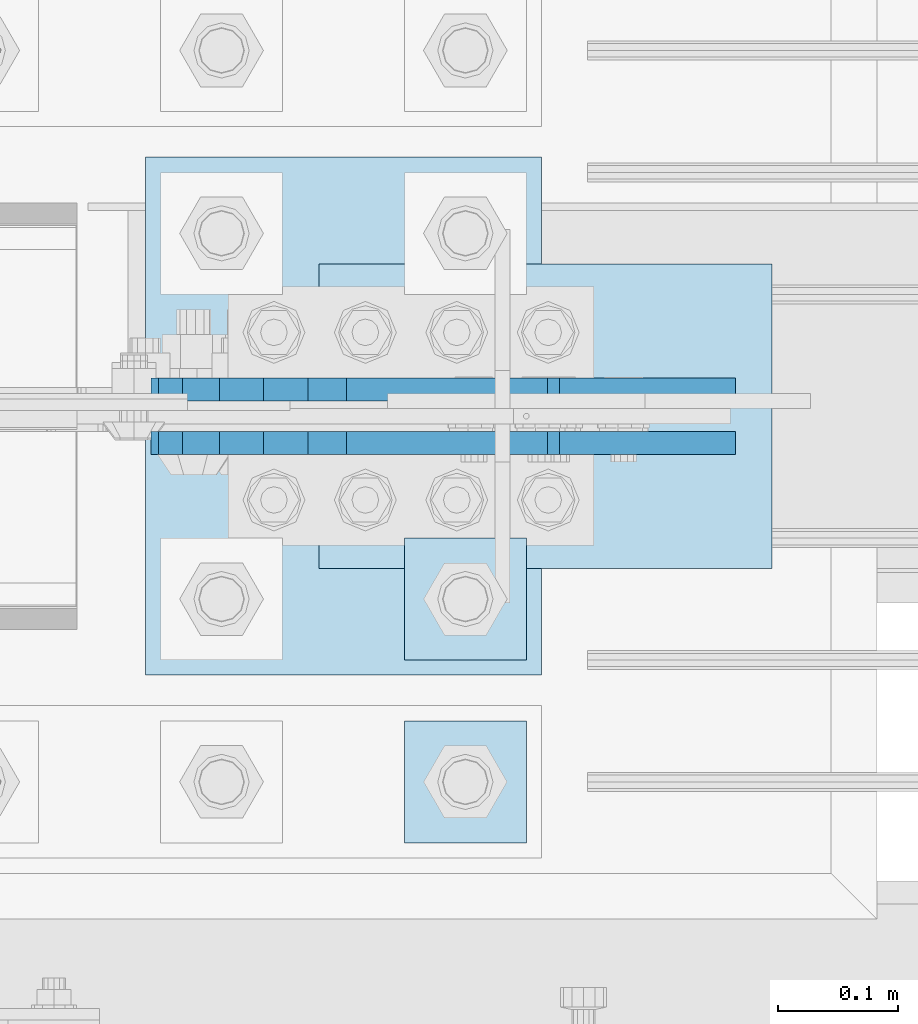
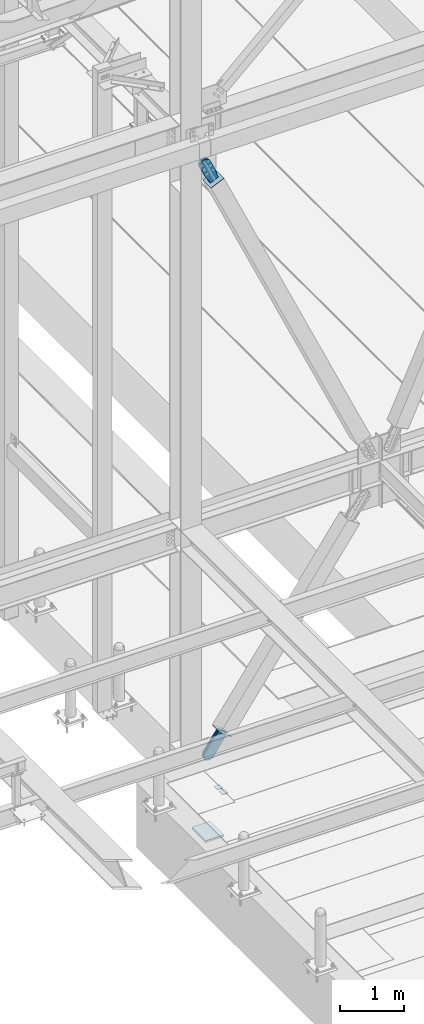
# One storey, part 3032 of 3843: 9 plates, 7 elements without a shape of their own.
"""IFC2X3 building model written with IfcOpenShell, lengths in millimetres."""

from ifc_helpers import new_model, si_unit, frame, origin_with_axes, place, context, subcontext, project, spatial, faceted_brep, material, type_object, element, aggregate, save


model = new_model("IFC2X3")

# Units and contexts
model_context = context("Model", 3, precision=1e-05, world=origin_with_axes())
body_context = subcontext(model_context, "Body", "Model", "MODEL_VIEW")
ifc_project = project(units=[si_unit("LENGTHUNIT", "METRE", prefix="MILLI"), si_unit("AREAUNIT", "SQUARE_METRE"), si_unit("VOLUMEUNIT", "CUBIC_METRE"), si_unit("MASSUNIT", "GRAM", prefix="KILO"), si_unit("TIMEUNIT", "SECOND"), si_unit("PLANEANGLEUNIT", "RADIAN"), si_unit("SOLIDANGLEUNIT", "STERADIAN"), si_unit("THERMODYNAMICTEMPERATUREUNIT", "DEGREE_CELSIUS"), si_unit("LUMINOUSINTENSITYUNIT", "LUMEN")], contexts=[model_context])

# Site, building, storey
site_placement = place(None, origin_with_axes())
site = spatial("IfcSite", under=ifc_project, at=site_placement, CompositionType="ELEMENT")
building_placement = place(site_placement, origin_with_axes())
building = spatial("IfcBuilding", under=site, at=building_placement, Name="Undefined", CompositionType="ELEMENT")
storey_placement = place(building_placement, origin_with_axes())
storey = spatial("IfcBuildingStorey", under=building, at=storey_placement, Name="Undefined", CompositionType="ELEMENT", Elevation=0.0)

# Assembly, plates
assembly_1_placement = place(storey_placement, origin_with_axes())
assembly_1 = element("IfcElementAssembly", 1, at=assembly_1_placement, inside=storey, Name="TEMPLATE", AssemblyPlace="NOTDEFINED", PredefinedType="RIGID_FRAME")
ifc_material_1 = material(Name="STEEL/A572-50")
plate_type_1 = type_object("IfcPlateType", PredefinedType="NOTDEFINED")
plate_1_placement = place(assembly_1_placement, frame((42621.2, 25361.9, 29686.25), z_axis=(-1.0, 0.0, 0.0), x_axis=(0.0, -1.0, 0.0)))
plate_1 = element("IfcPlate", 2, at=plate_1_placement, type_object=plate_type_1, material=ifc_material_1, Name="Washer Plate", context=body_context, shape_type="Brep", body=[
    faceted_brep([(0.0, -6.3499999046162, 0.0), (-1.67347025126219e-10, -6.35000000000582, 101.600000000151), (-1.67347025126219e-10, 6.35000000000582, 101.600000000151), (7.27595761418343e-12, 6.3499999046162, 0.0), (101.599998474121, -6.34999999999854, 101.599998474121), (101.599998474121, 6.34999999999854, 101.599998474121), (101.6, -6.34999999999854, 0.0), (101.6, 6.34999999999854, 0.0)], [[[0, 1, 2, 3]], [[1, 4, 5, 2]], [[4, 6, 7, 5]], [[6, 0, 3, 7]], [[5, 7, 3, 2]], [[6, 4, 1, 0]]]),
])
plate_2_placement = place(assembly_1_placement, frame((42621.2, 25514.3, 29686.25), z_axis=(-1.0, 0.0, 0.0), x_axis=(0.0, -1.0, 0.0)))
plate_2 = element("IfcPlate", 3, at=plate_2_placement, type_object=plate_type_1, material=ifc_material_1, Name="Washer Plate", context=body_context, shape_type="Brep", body=[
    faceted_brep([(0.0, -6.3499999046162, 0.0), (-1.67347025126219e-10, -6.35000000000582, 101.600000000151), (-1.67347025126219e-10, 6.35000000000582, 101.600000000151), (7.27595761418343e-12, 6.3499999046162, 0.0), (101.599998474121, -6.34999999999854, 101.599998474121), (101.599998474121, 6.34999999999854, 101.599998474121), (101.6, -6.34999999999854, 0.0), (101.6, 6.34999999999854, 0.0)], [[[0, 1, 2, 3]], [[1, 4, 5, 2]], [[4, 6, 7, 5]], [[6, 0, 3, 7]], [[5, 7, 3, 2]], [[6, 4, 1, 0]]]),
])

# Assembly, plate
assembly_2_placement = place(storey_placement, origin_with_axes())
assembly_2 = element("IfcElementAssembly", 4, at=assembly_2_placement, inside=storey, AssemblyPlace="NOTDEFINED", PredefinedType="RIGID_FRAME")
ifc_material_2 = material(Name="STEEL/A36")
plate_type_2 = type_object("IfcPlateType", PredefinedType="NOTDEFINED")
plate_3_placement = place(assembly_2_placement, frame((42755.4067779635, 25638.125, 30504.1943722968), z_axis=(-0.816439959974273, 0.0, 0.577430334981813), x_axis=(0.577430334981806, 0.0, 0.816439959974278)))
plate_3 = element("IfcPlate", 5, at=plate_3_placement, type_object=plate_type_2, material=ifc_material_2, context=body_context, shape_type="Brep", body=[
    faceted_brep([(0.0, -9.52500000000146, 0.0), (-101.59999999866, -9.52499999999418, -7.01164927375794), (-101.59999999866, 9.52499999999418, -7.01164927375794), (0.0, 9.52500000000146, 0.0), (-364.729297655074, -9.52499999999418, -7.01164927444188), (-364.729297655074, 9.52499999999418, -7.01164927444188), (-401.787405121293, -9.52499999999418, 0.359666612348519), (-401.787405121293, 9.52499999999418, 0.359666612348519), (-433.203751657995, -9.52499999999418, 21.3513982502482), (-433.203751657995, 9.52499999999418, 21.3513982502482), (-454.195483294687, -9.52499999999418, 52.7677447877504), (-454.195483294687, 9.52499999999418, 52.7677447877504), (-461.566799180051, -9.52499999999418, 89.8258492000314), (-461.566799180051, 9.52499999999418, 89.8258492000314), (-454.195483292249, -9.52499999999418, 126.883956664562), (-454.195483292249, 9.52499999999418, 126.883956664562), (-433.203751654662, -9.52499999999418, 158.300303199998), (-433.203751654662, 9.52499999999418, 158.300303199998), (-401.787405118426, -9.52499999999418, 179.292034836384), (-401.787405118426, 9.52499999999418, 179.292034836384), (-364.729299177612, -9.52499999999418, 186.663350722738), (-364.729299177612, 9.52499999999418, 186.663350722738), (-101.5999999907, -9.52499999999418, 186.663350723451), (-101.5999999907, 9.52499999999418, 186.663350723451), (7.37782102078199e-09, -9.52499999999418, 179.651701450231), (7.37782102078199e-09, 9.52499999999418, 179.651701450231), (69.8500000062704, -9.52499999999418, 179.651701450392), (69.8500000062704, 9.52499999999418, 179.651701450392), (69.8499999979995, -9.52499999999418, -4.00177668780088e-10), (69.8499999979995, 9.52499999999418, -4.00177668780088e-10)], [[[0, 1, 2, 3]], [[1, 4, 5, 2]], [[4, 6, 7, 5]], [[6, 8, 9, 7]], [[8, 10, 11, 9]], [[10, 12, 13, 11]], [[12, 14, 15, 13]], [[14, 16, 17, 15]], [[16, 18, 19, 17]], [[18, 20, 21, 19]], [[20, 22, 23, 21]], [[22, 24, 25, 23]], [[24, 26, 27, 25]], [[26, 28, 29, 27]], [[28, 0, 3, 29]], [[5, 7, 9, 11, 13, 15, 17, 19, 21, 23, 25, 27, 29, 3, 2]], [[28, 26, 24, 22, 20, 18, 16, 14, 12, 10, 8, 6, 4, 1, 0]]]),
])
aggregate(assembly_2, [plate_3])

assembly_3_placement = place(storey_placement, origin_with_axes())
assembly_3 = element("IfcElementAssembly", 6, at=assembly_3_placement, inside=storey, AssemblyPlace="NOTDEFINED", PredefinedType="RIGID_FRAME")
plate_4_placement = place(assembly_3_placement, frame((42755.4067779635, 25593.675, 30504.1943722968), z_axis=(-0.816439959974273, 0.0, 0.577430334981813), x_axis=(0.577430334981806, 0.0, 0.816439959974278)))
plate_4 = element("IfcPlate", 7, at=plate_4_placement, type_object=plate_type_2, material=ifc_material_2, context=body_context, shape_type="Brep", body=[
    faceted_brep([(0.0, -9.52500000000146, 0.0), (-101.59999999866, -9.52499999999418, -7.01164927375794), (-101.59999999866, 9.52499999999418, -7.01164927375794), (0.0, 9.52500000000146, 0.0), (-364.729297655074, -9.52499999999418, -7.01164927444188), (-364.729297655074, 9.52499999999418, -7.01164927444188), (-401.787405121293, -9.52499999999418, 0.359666612348519), (-401.787405121293, 9.52499999999418, 0.359666612348519), (-433.203751657995, -9.52499999999418, 21.3513982502482), (-433.203751657995, 9.52499999999418, 21.3513982502482), (-454.195483294687, -9.52499999999418, 52.7677447877504), (-454.195483294687, 9.52499999999418, 52.7677447877504), (-461.566799180051, -9.52499999999418, 89.8258492000314), (-461.566799180051, 9.52499999999418, 89.8258492000314), (-454.195483292249, -9.52499999999418, 126.883956664562), (-454.195483292249, 9.52499999999418, 126.883956664562), (-433.203751654662, -9.52499999999418, 158.300303199998), (-433.203751654662, 9.52499999999418, 158.300303199998), (-401.787405118426, -9.52499999999418, 179.292034836384), (-401.787405118426, 9.52499999999418, 179.292034836384), (-364.729299177612, -9.52499999999418, 186.663350722738), (-364.729299177612, 9.52499999999418, 186.663350722738), (-101.5999999907, -9.52499999999418, 186.663350723451), (-101.5999999907, 9.52499999999418, 186.663350723451), (7.37782102078199e-09, -9.52499999999418, 179.651701450231), (7.37782102078199e-09, 9.52499999999418, 179.651701450231), (69.8500000062704, -9.52499999999418, 179.651701450392), (69.8500000062704, 9.52499999999418, 179.651701450392), (69.8499999979995, -9.52499999999418, -4.00177668780088e-10), (69.8499999979995, 9.52499999999418, -4.00177668780088e-10)], [[[0, 1, 2, 3]], [[1, 4, 5, 2]], [[4, 6, 7, 5]], [[6, 8, 9, 7]], [[8, 10, 11, 9]], [[10, 12, 13, 11]], [[12, 14, 15, 13]], [[14, 16, 17, 15]], [[16, 18, 19, 17]], [[18, 20, 21, 19]], [[20, 22, 23, 21]], [[22, 24, 25, 23]], [[24, 26, 27, 25]], [[26, 28, 29, 27]], [[28, 0, 3, 29]], [[5, 7, 9, 11, 13, 15, 17, 19, 21, 23, 25, 27, 29, 3, 2]], [[28, 26, 24, 22, 20, 18, 16, 14, 12, 10, 8, 6, 4, 1, 0]]]),
])
aggregate(assembly_3, [plate_4])

assembly_4_placement = place(storey_placement, origin_with_axes())
assembly_4 = element("IfcElementAssembly", 8, at=assembly_4_placement, inside=storey, AssemblyPlace="NOTDEFINED", PredefinedType="RIGID_FRAME")
plate_5_placement = place(assembly_4_placement, frame((42609.8133617943, 25638.125, 41206.6621136179), z_axis=(-0.910599636162148, 0.0, -0.413289611073595), x_axis=(0.413289611073596, 0.0, -0.910599636162148)))
plate_5 = element("IfcPlate", 9, at=plate_5_placement, type_object=plate_type_2, material=ifc_material_2, context=body_context, shape_type="Brep", body=[
    faceted_brep([(0.0, -9.52500000000146, 0.0), (-101.599999999169, -9.52499999999418, -17.6403935107228), (-101.599999999169, 9.52499999999418, -17.6403935107228), (0.0, 9.52500000000146, 0.0), (-320.279297659972, -9.52499999999418, -17.640393512258), (-320.279297659972, 9.52499999999418, -17.640393512258), (-357.3374051259, -9.52499999999418, -10.2690776257878), (-357.3374051259, 9.52499999999418, -10.2690776257878), (-388.753751662653, -9.52499999999418, 10.7226540115298), (-388.753751662653, 9.52499999999418, 10.7226540115298), (-409.745483299826, -9.52499999999418, 42.1390005483918), (-409.745483299826, 9.52499999999418, 42.1390005483918), (-417.116799186137, -9.52499999999418, 79.1971049608474), (-417.116799186137, 9.52499999999418, 79.1971049608474), (-409.745483299252, -9.52499999999418, 116.255212426157), (-409.745483299252, 9.52499999999418, 116.255212426157), (-388.75375166202, -9.52499999999418, 147.671558962465), (-388.75375166202, 9.52499999999418, 147.671558962465), (-357.33740512564, -9.52499999999418, 168.663290599579), (-357.33740512564, 9.52499999999418, 168.663290599579), (-320.279299186061, -9.52499999999418, 176.034606486319), (-320.279299186061, 9.52499999999418, 176.034606486319), (-101.599999997048, -9.52499999999418, 176.034606487883), (-101.599999997048, 9.52499999999418, 176.034606487883), (1.71894498635083e-09, -9.52499999999418, 158.39421297863), (1.71894498635083e-09, 9.52499999999418, 158.39421297863), (69.8500000010408, -9.52499999999418, 158.394212979103), (69.8500000010408, 9.52499999999418, 158.394212979103), (69.8499999979995, -9.52499999999418, -4.00177668780088e-10), (69.8499999979995, 9.52499999999418, -4.00177668780088e-10)], [[[0, 1, 2, 3]], [[1, 4, 5, 2]], [[4, 6, 7, 5]], [[6, 8, 9, 7]], [[8, 10, 11, 9]], [[10, 12, 13, 11]], [[12, 14, 15, 13]], [[14, 16, 17, 15]], [[16, 18, 19, 17]], [[18, 20, 21, 19]], [[20, 22, 23, 21]], [[22, 24, 25, 23]], [[24, 26, 27, 25]], [[26, 28, 29, 27]], [[28, 0, 3, 29]], [[5, 7, 9, 11, 13, 15, 17, 19, 21, 23, 25, 27, 29, 3, 2]], [[28, 26, 24, 22, 20, 18, 16, 14, 12, 10, 8, 6, 4, 1, 0]]]),
])
aggregate(assembly_4, [plate_5])

assembly_5_placement = place(storey_placement, origin_with_axes())
assembly_5 = element("IfcElementAssembly", 10, at=assembly_5_placement, inside=storey, AssemblyPlace="NOTDEFINED", PredefinedType="RIGID_FRAME")
plate_6_placement = place(assembly_5_placement, frame((42609.8133617943, 25593.675, 41206.6621136179), z_axis=(-0.910599636162148, 0.0, -0.413289611073595), x_axis=(0.413289611073596, 0.0, -0.910599636162148)))
plate_6 = element("IfcPlate", 11, at=plate_6_placement, type_object=plate_type_2, material=ifc_material_2, context=body_context, shape_type="Brep", body=[
    faceted_brep([(0.0, -9.52500000000146, 0.0), (-101.599999999169, -9.52499999999418, -17.6403935107228), (-101.599999999169, 9.52499999999418, -17.6403935107228), (0.0, 9.52500000000146, 0.0), (-320.279297659972, -9.52499999999418, -17.640393512258), (-320.279297659972, 9.52499999999418, -17.640393512258), (-357.3374051259, -9.52499999999418, -10.2690776257878), (-357.3374051259, 9.52499999999418, -10.2690776257878), (-388.753751662653, -9.52499999999418, 10.7226540115298), (-388.753751662653, 9.52499999999418, 10.7226540115298), (-409.745483299826, -9.52499999999418, 42.1390005483918), (-409.745483299826, 9.52499999999418, 42.1390005483918), (-417.116799186137, -9.52499999999418, 79.1971049608474), (-417.116799186137, 9.52499999999418, 79.1971049608474), (-409.745483299252, -9.52499999999418, 116.255212426157), (-409.745483299252, 9.52499999999418, 116.255212426157), (-388.75375166202, -9.52499999999418, 147.671558962465), (-388.75375166202, 9.52499999999418, 147.671558962465), (-357.33740512564, -9.52499999999418, 168.663290599579), (-357.33740512564, 9.52499999999418, 168.663290599579), (-320.279299186061, -9.52499999999418, 176.034606486319), (-320.279299186061, 9.52499999999418, 176.034606486319), (-101.599999997048, -9.52499999999418, 176.034606487883), (-101.599999997048, 9.52499999999418, 176.034606487883), (1.71894498635083e-09, -9.52499999999418, 158.39421297863), (1.71894498635083e-09, 9.52499999999418, 158.39421297863), (69.8500000010408, -9.52499999999418, 158.394212979103), (69.8500000010408, 9.52499999999418, 158.394212979103), (69.8499999979995, -9.52499999999418, -4.00177668780088e-10), (69.8499999979995, 9.52499999999418, -4.00177668780088e-10)], [[[0, 1, 2, 3]], [[1, 4, 5, 2]], [[4, 6, 7, 5]], [[6, 8, 9, 7]], [[8, 10, 11, 9]], [[10, 12, 13, 11]], [[12, 14, 15, 13]], [[14, 16, 17, 15]], [[16, 18, 19, 17]], [[18, 20, 21, 19]], [[20, 22, 23, 21]], [[22, 24, 25, 23]], [[24, 26, 27, 25]], [[26, 28, 29, 27]], [[28, 0, 3, 29]], [[5, 7, 9, 11, 13, 15, 17, 19, 21, 23, 25, 27, 29, 3, 2]], [[28, 26, 24, 22, 20, 18, 16, 14, 12, 10, 8, 6, 4, 1, 0]]]),
])
aggregate(assembly_5, [plate_6])

assembly_6_placement = place(storey_placement, origin_with_axes())
assembly_6 = element("IfcElementAssembly", 12, at=assembly_6_placement, inside=storey, Name="Plate", AssemblyPlace="NOTDEFINED", PredefinedType="RIGID_FRAME")
plate_type_3 = type_object("IfcPlateType", PredefinedType="NOTDEFINED")
plate_7_placement = place(assembly_6_placement, frame((42824.2574060716, 25488.9, 30537.165025457), z_axis=(-0.816439959974273, 0.0, 0.577430334981813), x_axis=(0.0, 1.0, 0.0)))
plate_7 = element("IfcPlate", 13, at=plate_7_placement, type_object=plate_type_3, material=ifc_material_2, Name="Plate", context=body_context, shape_type="Brep", body=[
    faceted_brep([(0.0, -3.17499999999927, 0.0), (0.0, -3.17499999965185, 254.000000005151), (0.0, 3.17500000035216, 254.000000005166), (0.0, 3.17499999999927, 0.0), (254.0, -3.17499999965185, 254.000000005151), (254.0, 3.17500000035216, 254.000000005166), (254.0, -3.17500000000291, 0.0), (254.0, 3.17499999999927, 1.45519152283669e-11)], [[[0, 1, 2, 3]], [[1, 4, 5, 2]], [[4, 6, 7, 5]], [[6, 0, 3, 7]], [[5, 7, 3, 2]], [[6, 4, 1, 0]]]),
])
aggregate(assembly_6, [plate_7])

assembly_7_placement = place(storey_placement, origin_with_axes())
assembly_7 = element("IfcElementAssembly", 14, at=assembly_7_placement, inside=storey, Name="Plate", AssemblyPlace="NOTDEFINED", PredefinedType="RIGID_FRAME")
plate_8_placement = place(assembly_7_placement, frame((42449.6064366571, 25742.9, 41060.7287610197), z_axis=(0.910599636162148, 0.0, 0.413289611073595), x_axis=(0.0, -1.0, 0.0)))
plate_8 = element("IfcPlate", 15, at=plate_8_placement, type_object=plate_type_3, material=ifc_material_2, Name="Plate", context=body_context, shape_type="Brep", body=[
    faceted_brep([(0.0, -3.17499999999927, 0.0), (0.0, -3.17499999965185, 254.000000005151), (0.0, 3.17500000035216, 254.000000005166), (0.0, 3.17499999999927, 0.0), (254.0, -3.17499999965185, 254.000000005151), (254.0, 3.17500000035216, 254.000000005166), (254.0, -3.17500000000291, 0.0), (254.0, 3.17499999999927, 1.45519152283669e-11)], [[[0, 1, 2, 3]], [[1, 4, 5, 2]], [[4, 6, 7, 5]], [[6, 0, 3, 7]], [[5, 7, 3, 2]], [[6, 4, 1, 0]]]),
])
aggregate(assembly_7, [plate_8])

# Plate
plate_type_4 = type_object("IfcPlateType", PredefinedType="NOTDEFINED")
plate_9_placement = place(assembly_1_placement, frame((42303.7, 25831.8, 28784.55), z_axis=(1.0, 0.0, 0.0), x_axis=(0.0, -1.0, 0.0)))
plate_9 = element("IfcPlate", 16, at=plate_9_placement, type_object=plate_type_4, material=ifc_material_1, Name="PLATE", context=body_context, shape_type="Brep", body=[
    faceted_brep([(0.0, -19.0500000000029, 0.0), (0.0, -19.0499999999993, 330.200012207031), (0.0, 19.0499999999993, 330.200012207031), (0.0, 19.0500000000029, 0.0), (431.799957275391, -19.0499999999993, 330.200012207031), (431.799957275391, 19.0499999999993, 330.200012207031), (431.799957275391, -19.0499999999993, 0.0), (431.799957275391, 19.0499999999993, 0.0)], [[[0, 1, 2, 3]], [[1, 4, 5, 2]], [[4, 6, 7, 5]], [[6, 0, 3, 7]], [[5, 7, 3, 2]], [[6, 4, 1, 0]]]),
])

aggregate(assembly_1, [plate_9, plate_1, plate_2])

save(model, "model.ifc")
